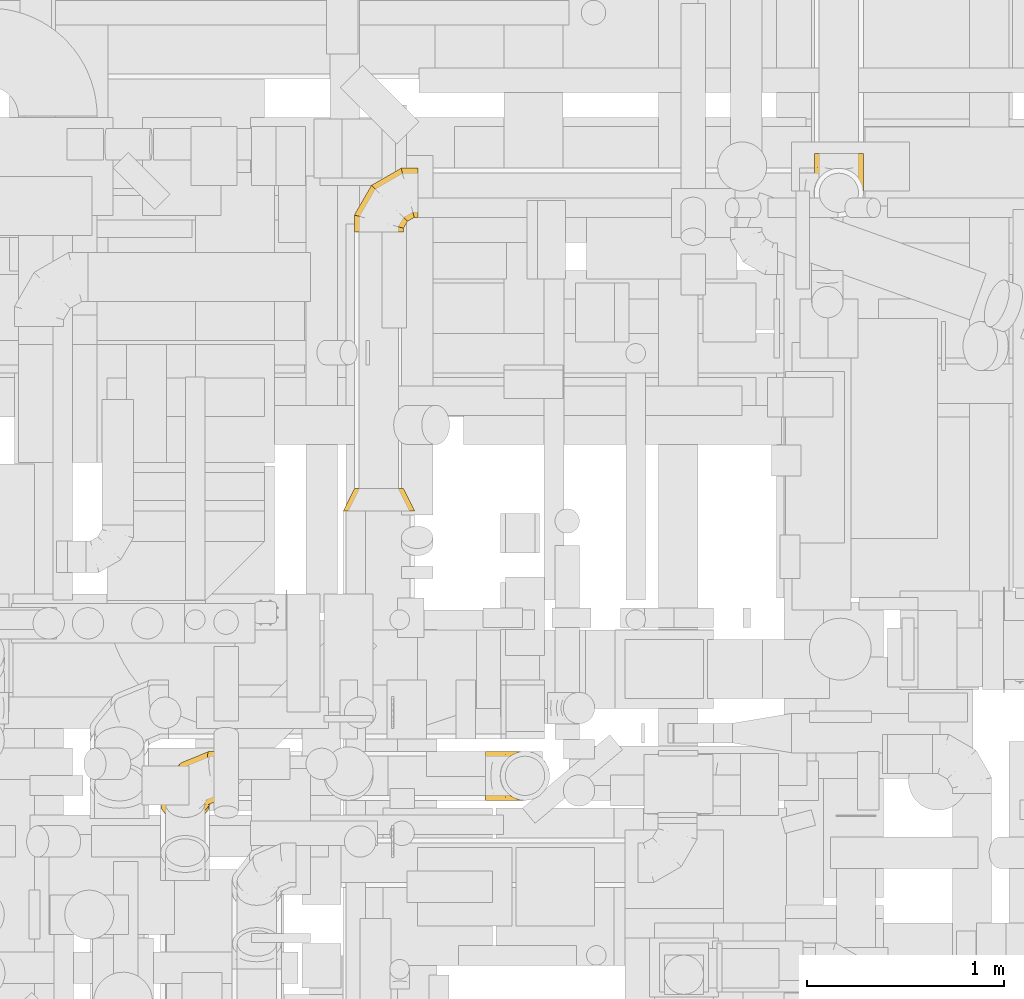
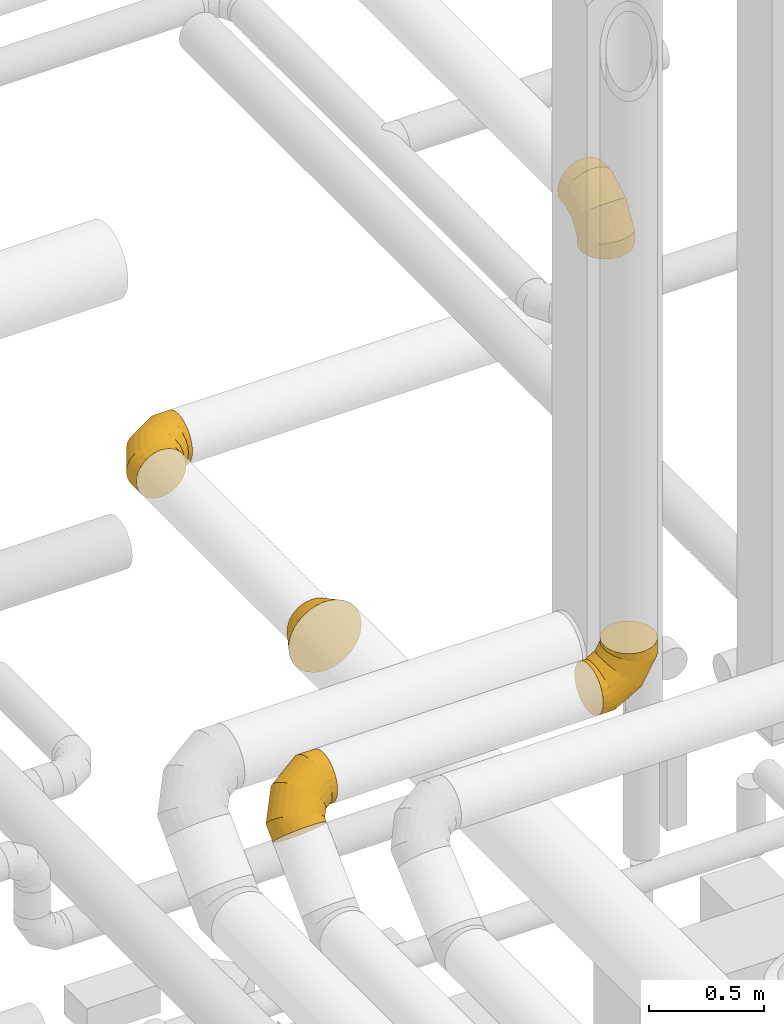
# One storey, part 10 of 337: 5 coverings.
"""IFC2X3 building model written with IfcOpenShell, lengths in millimetres."""

from ifc_helpers import new_model, entity, si_unit, converted_unit, derived_unit, direction, frame, origin, place, context, subcontext, project, spatial, faceted_brep, element, save


model = new_model("IFC2X3")

# Units and contexts
model_context = context("Model", 3, precision=0.01, world=origin(), true_north=direction((6.12303176911189e-17, 1.0)))
body_context = subcontext(model_context, "Body", "Model", "MODEL_VIEW")
ifc_project = project(units=[si_unit("LENGTHUNIT", "METRE", prefix="MILLI"), si_unit("AREAUNIT", "SQUARE_METRE"), si_unit("VOLUMEUNIT", "CUBIC_METRE"), converted_unit("PLANEANGLEUNIT", "DEGREE", entity("IfcRatioMeasure", 0.0174532925199433), si_unit("PLANEANGLEUNIT", "RADIAN"), dimensions=[0, 0, 0, 0, 0, 0, 0]), si_unit("MASSUNIT", "GRAM", prefix="KILO"), derived_unit("MASSDENSITYUNIT", [(si_unit("MASSUNIT", "GRAM", prefix="KILO"), 1), (si_unit("LENGTHUNIT", "METRE"), -3)]), derived_unit("MOMENTOFINERTIAUNIT", [(si_unit("LENGTHUNIT", "METRE"), 4)]), si_unit("TIMEUNIT", "SECOND"), si_unit("FREQUENCYUNIT", "HERTZ"), si_unit("THERMODYNAMICTEMPERATUREUNIT", "DEGREE_CELSIUS"), derived_unit("THERMALTRANSMITTANCEUNIT", [(si_unit("MASSUNIT", "GRAM", prefix="KILO"), 1), (si_unit("THERMODYNAMICTEMPERATUREUNIT", "KELVIN"), -1), (si_unit("TIMEUNIT", "SECOND"), -3)]), derived_unit("VOLUMETRICFLOWRATEUNIT", [(si_unit("LENGTHUNIT", "METRE"), 3), (si_unit("TIMEUNIT", "SECOND"), -1)]), derived_unit("MASSFLOWRATEUNIT", [(si_unit("MASSUNIT", "GRAM", prefix="KILO"), 1), (si_unit("TIMEUNIT", "SECOND"), -1)]), derived_unit("ROTATIONALFREQUENCYUNIT", [(si_unit("TIMEUNIT", "SECOND"), -1)]), si_unit("ELECTRICCURRENTUNIT", "AMPERE"), si_unit("ELECTRICVOLTAGEUNIT", "VOLT"), si_unit("POWERUNIT", "WATT"), si_unit("FORCEUNIT", "NEWTON", prefix="KILO"), si_unit("ILLUMINANCEUNIT", "LUX"), si_unit("LUMINOUSFLUXUNIT", "LUMEN"), si_unit("LUMINOUSINTENSITYUNIT", "CANDELA"), derived_unit("USERDEFINED", [(si_unit("MASSUNIT", "GRAM", prefix="KILO"), -1), (si_unit("LENGTHUNIT", "METRE"), -2), (si_unit("TIMEUNIT", "SECOND"), 3), (si_unit("LUMINOUSFLUXUNIT", "LUMEN"), 1)]), derived_unit("LINEARVELOCITYUNIT", [(si_unit("LENGTHUNIT", "METRE"), 1), (si_unit("TIMEUNIT", "SECOND"), -1)]), si_unit("PRESSUREUNIT", "PASCAL"), derived_unit("USERDEFINED", [(si_unit("LENGTHUNIT", "METRE"), -2), (si_unit("MASSUNIT", "GRAM", prefix="KILO"), 1), (si_unit("TIMEUNIT", "SECOND"), -2)]), derived_unit("LINEARFORCEUNIT", [(si_unit("MASSUNIT", "GRAM", prefix="KILO"), 1), (si_unit("LENGTHUNIT", "METRE"), 1), (si_unit("TIMEUNIT", "SECOND"), -2), (si_unit("LENGTHUNIT", "METRE"), -1)]), derived_unit("PLANARFORCEUNIT", [(si_unit("MASSUNIT", "GRAM", prefix="KILO"), 1), (si_unit("LENGTHUNIT", "METRE"), 1), (si_unit("TIMEUNIT", "SECOND"), -2), (si_unit("LENGTHUNIT", "METRE"), -2)])], contexts=[model_context])

# Site, building, storey
site_placement = place(None, origin())
site = spatial("IfcSite", under=ifc_project, at=site_placement, CompositionType="ELEMENT")
building_placement = place(site_placement, origin())
building = spatial("IfcBuilding", under=site, at=building_placement, CompositionType="ELEMENT")
storey_placement = place(building_placement, origin())
storey = spatial("IfcBuildingStorey", under=building, at=storey_placement, CompositionType="ELEMENT", Elevation=0.0)

# Coverings
covering_1_placement = place(storey_placement, frame((53261.67, 15088.48, 3380.0)))
element("IfcCovering", 1, at=covering_1_placement, inside=storey, PredefinedType="INSULATION", context=body_context, shape_type="Brep", body=[
    faceted_brep([(251.6, 126.6, 0.0), (245.48, 87.97, 0.0), (227.72, 53.12, 0.0), (200.07, 25.47, 0.0), (165.22, 7.71, 0.0), (126.6, 1.6, 0.0), (87.97, 7.71, 0.0), (53.12, 25.47, 0.0), (25.47, 53.12, 0.0), (7.71, 87.97, 0.0), (1.6, 126.6, 0.0), (7.71, 165.22, 0.0), (25.47, 200.07, 0.0), (53.12, 227.72, 0.0), (87.97, 245.48, 0.0), (126.6, 251.6, 0.0), (165.22, 245.48, 0.0), (200.07, 227.72, 0.0), (227.72, 200.07, 0.0), (245.48, 165.22, 0.0), (64.1, 326.6, 308.25), (94.24, 326.6, 320.74), (126.6, 326.6, 325.0), (158.95, 326.6, 320.74), (189.1, 326.6, 308.25), (214.98, 326.6, 288.39), (234.85, 326.6, 262.5), (247.34, 326.6, 232.35), (251.6, 326.6, 200.0), (247.34, 326.6, 167.65), (234.85, 326.6, 137.5), (214.98, 326.6, 111.61), (189.1, 326.6, 91.75), (158.95, 326.6, 79.26), (126.6, 326.6, 75.0), (94.24, 326.6, 79.26), (64.1, 326.6, 91.75), (38.21, 326.6, 111.61), (18.34, 326.6, 137.5), (5.85, 326.6, 167.65), (1.6, 326.6, 200.0), (5.85, 326.6, 232.35), (18.34, 326.6, 262.5), (38.21, 326.6, 288.39), (126.6, 239.51, 325.0), (158.95, 240.65, 320.74), (189.1, 244.0, 308.25), (214.98, 249.32, 288.39), (234.85, 256.26, 262.5), (247.34, 264.34, 232.35), (251.6, 273.01, 200.0), (247.34, 281.67, 167.65), (234.85, 289.75, 137.5), (214.98, 296.69, 111.61), (189.1, 302.01, 91.75), (158.95, 305.36, 79.26), (126.6, 306.5, 75.0), (94.24, 305.36, 79.26), (64.1, 302.01, 91.75), (38.21, 296.69, 111.61), (5.85, 281.67, 167.65), (1.6, 273.01, 200.0), (18.34, 289.75, 137.5), (5.85, 264.34, 232.35), (18.34, 256.26, 262.5), (38.21, 249.32, 288.39), (64.1, 244.0, 308.25), (94.24, 240.65, 320.74), (126.6, 88.68, 237.92), (158.95, 91.8, 234.8), (189.1, 100.94, 225.66), (214.98, 115.48, 211.11), (234.85, 134.43, 192.16), (247.34, 156.5, 170.09), (251.6, 180.19, 146.41), (247.34, 203.87, 122.73), (234.85, 225.94, 100.66), (214.98, 244.89, 81.71), (189.1, 259.43, 67.16), (158.95, 268.57, 58.02), (126.6, 271.69, 54.9), (94.24, 268.57, 58.02), (64.1, 259.43, 67.16), (38.21, 244.89, 81.71), (5.85, 203.87, 122.73), (1.6, 180.19, 146.41), (18.34, 225.94, 100.66), (5.85, 156.5, 170.09), (18.34, 134.43, 192.16), (38.21, 115.48, 211.11), (64.1, 100.94, 225.66), (94.24, 91.8, 234.8), (126.6, 1.6, 87.08), (158.95, 5.85, 85.94), (189.1, 18.34, 82.6), (214.98, 38.21, 77.27), (234.85, 64.1, 70.34), (247.34, 94.24, 62.26), (251.6, 126.6, 53.59), (247.34, 158.95, 44.92), (234.85, 189.1, 36.84), (214.98, 214.98, 29.91), (189.1, 234.85, 24.58), (158.95, 247.34, 21.24), (126.6, 251.6, 20.1), (94.24, 247.34, 21.24), (64.1, 234.85, 24.58), (38.21, 214.98, 29.91), (5.85, 158.95, 44.92), (1.6, 126.6, 53.59), (18.34, 189.1, 36.84), (5.85, 94.24, 62.26), (18.34, 64.1, 70.34), (38.21, 38.21, 77.27), (64.1, 18.34, 82.6), (94.24, 5.85, 85.94)], [[[0, 1, 2, 3, 4, 5, 6, 7, 8, 9, 10, 11, 12, 13, 14, 15, 16, 17, 18, 19]], [[20, 21, 22, 23, 24, 25, 26, 27, 28, 29, 30, 31, 32, 33, 34, 35, 36, 37, 38, 39, 40, 41, 42, 43]], [[22, 44, 45, 23]], [[23, 45, 46, 24]], [[47, 25, 24, 46]], [[25, 47, 48, 26]], [[26, 48, 49, 27]], [[50, 28, 27, 49]], [[51, 52, 30, 29]], [[50, 51, 29, 28]], [[53, 31, 30, 52]], [[54, 55, 33, 32]], [[54, 32, 31, 53]], [[56, 34, 33, 55]], [[57, 58, 36, 35]], [[56, 57, 35, 34]], [[37, 36, 58, 59]], [[60, 61, 40, 39]], [[62, 60, 39, 38]], [[59, 62, 38, 37]], [[41, 40, 61, 63]], [[42, 41, 63, 64]], [[64, 65, 43, 42]], [[21, 20, 66, 67]], [[22, 21, 67, 44]], [[65, 66, 20, 43]], [[45, 44, 68, 69]], [[46, 45, 69, 70]], [[70, 71, 47, 46]], [[48, 47, 71, 72]], [[49, 48, 72, 73]], [[50, 49, 73, 74]], [[75, 76, 52, 51]], [[74, 75, 51, 50]], [[53, 52, 76, 77]], [[78, 79, 55, 54]], [[77, 78, 54, 53]], [[56, 55, 79, 80]], [[81, 82, 58, 57]], [[80, 81, 57, 56]], [[59, 58, 82, 83]], [[84, 85, 61, 60]], [[86, 84, 60, 62]], [[83, 86, 62, 59]], [[63, 61, 85, 87]], [[64, 63, 87, 88]], [[65, 64, 88, 89]], [[67, 66, 90, 91]], [[44, 67, 91, 68]], [[89, 90, 66, 65]], [[69, 68, 92, 93]], [[70, 69, 93, 94]], [[94, 95, 71, 70]], [[72, 71, 95, 96]], [[73, 72, 96, 97]], [[74, 73, 97, 98]], [[99, 100, 76, 75]], [[98, 99, 75, 74]], [[77, 76, 100, 101]], [[102, 103, 79, 78]], [[101, 102, 78, 77]], [[80, 79, 103, 104]], [[105, 106, 82, 81]], [[104, 105, 81, 80]], [[83, 82, 106, 107]], [[108, 109, 85, 84]], [[110, 108, 84, 86]], [[107, 110, 86, 83]], [[87, 85, 109, 111]], [[88, 87, 111, 112]], [[89, 88, 112, 113]], [[91, 90, 114, 115]], [[68, 91, 115, 92]], [[113, 114, 90, 89]], [[93, 5, 4]], [[94, 4, 3]], [[5, 93, 92]], [[93, 4, 94]], [[3, 95, 94]], [[96, 2, 1]], [[97, 1, 0]], [[95, 2, 96]], [[96, 1, 97]], [[0, 98, 97]], [[2, 95, 3]], [[99, 0, 19]], [[100, 19, 18]], [[99, 98, 0]], [[100, 99, 19]], [[18, 101, 100]], [[16, 15, 103]], [[17, 16, 102]], [[102, 101, 17]], [[104, 103, 15]], [[102, 16, 103]], [[17, 101, 18]], [[105, 15, 14]], [[106, 14, 13]], [[105, 104, 15]], [[106, 105, 14]], [[13, 107, 106]], [[110, 12, 11]], [[108, 11, 10]], [[110, 107, 12]], [[109, 108, 10]], [[110, 11, 108]], [[12, 107, 13]], [[111, 10, 9]], [[112, 9, 8]], [[10, 111, 109]], [[111, 9, 112]], [[8, 113, 112]], [[114, 7, 6]], [[115, 6, 5]], [[113, 7, 114]], [[115, 114, 6]], [[92, 115, 5]], [[7, 113, 8]]]),
])
covering_2_placement = place(storey_placement, frame((50921.67, 15015.07, 2973.38)))
element("IfcCovering", 2, at=covering_2_placement, inside=storey, PredefinedType="INSULATION", context=body_context, shape_type="Brep", body=[
    faceted_brep([(126.6, 0.0, 251.6), (87.97, 0.0, 245.48), (53.12, 0.0, 227.72), (25.47, 0.0, 200.07), (7.71, 0.0, 165.22), (1.6, 0.0, 126.6), (7.71, 0.0, 87.97), (25.47, 0.0, 53.12), (53.12, 0.0, 25.47), (87.97, 0.0, 7.71), (126.6, 0.0, 1.6), (165.22, 0.0, 7.71), (200.07, 0.0, 25.47), (227.72, 0.0, 53.12), (245.48, 0.0, 87.97), (251.6, 0.0, 126.6), (245.48, 0.0, 165.22), (227.72, 0.0, 200.07), (200.07, 0.0, 227.72), (165.22, 0.0, 245.48), (326.6, 308.25, 64.1), (326.6, 320.74, 94.24), (326.6, 325.0, 126.6), (326.6, 320.74, 158.95), (326.6, 308.25, 189.1), (326.6, 288.39, 214.98), (326.6, 262.5, 234.85), (326.6, 232.35, 247.34), (326.6, 200.0, 251.6), (326.6, 167.65, 247.34), (326.6, 137.5, 234.85), (326.6, 111.61, 214.98), (326.6, 91.75, 189.1), (326.6, 79.26, 158.95), (326.6, 75.0, 126.6), (326.6, 79.26, 94.24), (326.6, 91.75, 64.1), (326.6, 111.61, 38.21), (326.6, 137.5, 18.34), (326.6, 167.65, 5.85), (326.6, 200.0, 1.6), (326.6, 232.35, 5.85), (326.6, 262.5, 18.34), (326.6, 288.39, 38.21), (239.51, 325.0, 126.6), (240.65, 320.74, 158.95), (244.0, 308.25, 189.1), (249.32, 288.39, 214.98), (256.26, 262.5, 234.85), (264.34, 232.35, 247.34), (273.01, 200.0, 251.6), (281.67, 167.65, 247.34), (289.75, 137.5, 234.85), (296.69, 111.61, 214.98), (302.01, 91.75, 189.1), (305.36, 79.26, 158.95), (306.5, 75.0, 126.6), (305.36, 79.26, 94.24), (302.01, 91.75, 64.1), (296.69, 111.61, 38.21), (281.67, 167.65, 5.85), (273.01, 200.0, 1.6), (289.75, 137.5, 18.34), (264.34, 232.35, 5.85), (256.26, 262.5, 18.34), (249.32, 288.39, 38.21), (244.0, 308.25, 64.1), (240.65, 320.74, 94.24), (88.68, 237.92, 126.6), (91.8, 234.8, 158.95), (100.94, 225.66, 189.1), (115.48, 211.11, 214.98), (134.43, 192.16, 234.85), (156.5, 170.09, 247.34), (180.19, 146.41, 251.6), (203.87, 122.73, 247.34), (225.94, 100.66, 234.85), (244.89, 81.71, 214.98), (259.43, 67.16, 189.1), (268.57, 58.02, 158.95), (271.69, 54.9, 126.6), (268.57, 58.02, 94.24), (259.43, 67.16, 64.1), (244.89, 81.71, 38.21), (203.87, 122.73, 5.85), (180.19, 146.41, 1.6), (225.94, 100.66, 18.34), (156.5, 170.09, 5.85), (134.43, 192.16, 18.34), (115.48, 211.11, 38.21), (100.94, 225.66, 64.1), (91.8, 234.8, 94.24), (1.6, 87.08, 126.6), (5.85, 85.94, 158.95), (18.34, 82.6, 189.1), (38.21, 77.27, 214.98), (64.1, 70.34, 234.85), (94.24, 62.26, 247.34), (126.6, 53.59, 251.6), (158.95, 44.92, 247.34), (189.1, 36.84, 234.85), (214.98, 29.91, 214.98), (234.85, 24.58, 189.1), (247.34, 21.24, 158.95), (251.6, 20.1, 126.6), (247.34, 21.24, 94.24), (234.85, 24.58, 64.1), (214.98, 29.91, 38.21), (158.95, 44.92, 5.85), (126.6, 53.59, 1.6), (189.1, 36.84, 18.34), (94.24, 62.26, 5.85), (64.1, 70.34, 18.34), (38.21, 77.27, 38.21), (18.34, 82.6, 64.1), (5.85, 85.94, 94.24)], [[[0, 1, 2, 3, 4, 5, 6, 7, 8, 9, 10, 11, 12, 13, 14, 15, 16, 17, 18, 19]], [[20, 21, 22, 23, 24, 25, 26, 27, 28, 29, 30, 31, 32, 33, 34, 35, 36, 37, 38, 39, 40, 41, 42, 43]], [[22, 44, 45, 23]], [[23, 45, 46, 24]], [[47, 25, 24, 46]], [[25, 47, 48, 26]], [[26, 48, 49, 27]], [[50, 28, 27, 49]], [[51, 52, 30, 29]], [[50, 51, 29, 28]], [[53, 31, 30, 52]], [[54, 55, 33, 32]], [[54, 32, 31, 53]], [[56, 34, 33, 55]], [[57, 58, 36, 35]], [[56, 57, 35, 34]], [[37, 36, 58, 59]], [[60, 61, 40, 39]], [[62, 60, 39, 38]], [[59, 62, 38, 37]], [[41, 40, 61, 63]], [[42, 41, 63, 64]], [[64, 65, 43, 42]], [[21, 20, 66, 67]], [[22, 21, 67, 44]], [[65, 66, 20, 43]], [[45, 44, 68, 69]], [[46, 45, 69, 70]], [[70, 71, 47, 46]], [[48, 47, 71, 72]], [[49, 48, 72, 73]], [[50, 49, 73, 74]], [[75, 76, 52, 51]], [[74, 75, 51, 50]], [[53, 52, 76, 77]], [[78, 79, 55, 54]], [[77, 78, 54, 53]], [[56, 55, 79, 80]], [[81, 82, 58, 57]], [[80, 81, 57, 56]], [[59, 58, 82, 83]], [[84, 85, 61, 60]], [[86, 84, 60, 62]], [[83, 86, 62, 59]], [[63, 61, 85, 87]], [[64, 63, 87, 88]], [[65, 64, 88, 89]], [[67, 66, 90, 91]], [[44, 67, 91, 68]], [[89, 90, 66, 65]], [[69, 68, 92, 93]], [[70, 69, 93, 94]], [[94, 95, 71, 70]], [[72, 71, 95, 96]], [[73, 72, 96, 97]], [[74, 73, 97, 98]], [[99, 100, 76, 75]], [[98, 99, 75, 74]], [[77, 76, 100, 101]], [[102, 103, 79, 78]], [[101, 102, 78, 77]], [[80, 79, 103, 104]], [[105, 106, 82, 81]], [[104, 105, 81, 80]], [[83, 82, 106, 107]], [[108, 109, 85, 84]], [[110, 108, 84, 86]], [[107, 110, 86, 83]], [[87, 85, 109, 111]], [[88, 87, 111, 112]], [[89, 88, 112, 113]], [[91, 90, 114, 115]], [[68, 91, 115, 92]], [[113, 114, 90, 89]], [[93, 5, 4]], [[94, 4, 3]], [[5, 93, 92]], [[93, 4, 94]], [[3, 95, 94]], [[96, 2, 1]], [[97, 1, 0]], [[95, 2, 96]], [[96, 1, 97]], [[0, 98, 97]], [[2, 95, 3]], [[99, 0, 19]], [[100, 19, 18]], [[99, 98, 0]], [[100, 99, 19]], [[18, 101, 100]], [[16, 15, 103]], [[17, 16, 102]], [[102, 101, 17]], [[104, 103, 15]], [[102, 16, 103]], [[17, 101, 18]], [[105, 15, 14]], [[106, 14, 13]], [[105, 104, 15]], [[106, 105, 14]], [[13, 107, 106]], [[110, 12, 11]], [[108, 11, 10]], [[110, 107, 12]], [[109, 108, 10]], [[110, 11, 108]], [[12, 107, 13]], [[111, 10, 9]], [[112, 9, 8]], [[10, 111, 109]], [[111, 9, 112]], [[8, 113, 112]], [[114, 7, 6]], [[115, 6, 5]], [[113, 7, 114]], [[115, 114, 6]], [[92, 115, 5]], [[7, 113, 8]]]),
])
covering_3_placement = place(storey_placement, frame((50864.17, 13595.07, 2915.88)))
element("IfcCovering", 3, at=covering_3_placement, inside=storey, PredefinedType="INSULATION", context=body_context, shape_type="Brep", body=[
    faceted_brep([(184.1, 115.0, 309.1), (222.72, 115.0, 302.98), (257.57, 115.0, 285.22), (271.4, 115.0, 271.4), (285.22, 115.0, 257.57), (302.98, 115.0, 222.72), (309.1, 115.0, 184.1), (302.98, 115.0, 145.47), (285.22, 115.0, 110.62), (271.4, 115.0, 96.8), (257.57, 115.0, 82.97), (222.72, 115.0, 65.21), (184.1, 115.0, 59.1), (145.47, 115.0, 65.21), (110.62, 115.0, 82.97), (96.8, 115.0, 96.8), (82.97, 115.0, 110.62), (65.21, 115.0, 145.47), (59.1, 115.0, 184.1), (65.21, 115.0, 222.72), (82.97, 115.0, 257.57), (96.8, 115.0, 271.4), (110.62, 115.0, 285.22), (145.47, 115.0, 302.98), (136.86, 0.0, 360.38), (92.85, 0.0, 342.14), (55.05, 0.0, 313.14), (26.05, 0.0, 275.35), (7.81, 0.0, 231.33), (1.6, 0.0, 184.1), (7.81, 0.0, 136.86), (26.05, 0.0, 92.85), (55.05, 0.0, 55.05), (92.85, 0.0, 26.05), (136.86, 0.0, 7.81), (184.1, 0.0, 1.6), (231.33, 0.0, 7.81), (275.35, 0.0, 26.05), (313.14, 0.0, 55.05), (342.14, 0.0, 92.85), (360.38, 0.0, 136.86), (366.6, 0.0, 184.1), (360.38, 0.0, 231.33), (342.14, 0.0, 275.35), (313.14, 0.0, 313.14), (275.35, 0.0, 342.14), (231.33, 0.0, 360.38), (184.1, 0.0, 366.6), (335.62, 56.45, 155.07), (327.19, 78.81, 184.1), (328.08, 53.31, 124.46), (312.09, 56.04, 97.6), (184.1, 78.81, 41.0), (213.12, 56.45, 32.57), (243.73, 53.31, 40.11), (293.1, 56.68, 75.09), (270.59, 56.04, 56.1), (155.07, 56.45, 32.57), (124.46, 53.31, 40.11), (97.6, 56.04, 56.1), (41.0, 78.81, 184.1), (32.57, 56.45, 155.07), (40.11, 53.31, 124.46), (75.09, 56.68, 75.09), (56.1, 56.04, 97.6), (32.57, 56.45, 213.12), (40.11, 53.31, 243.74), (56.1, 56.04, 270.59), (184.1, 78.81, 327.19), (155.07, 56.45, 335.62), (124.46, 53.31, 328.08), (75.09, 56.68, 293.1), (97.6, 56.04, 312.09), (213.12, 56.45, 335.62), (243.73, 53.31, 328.08), (270.59, 56.04, 312.09), (335.62, 56.45, 213.12), (328.08, 53.31, 243.74), (293.1, 56.68, 293.1), (312.09, 56.04, 270.59)], [[[0, 1, 2, 3, 4, 5, 6, 7, 8, 9, 10, 11, 12, 13, 14, 15, 16, 17, 18, 19, 20, 21, 22, 23]], [[24, 25, 26, 27, 28, 29, 30, 31, 32, 33, 34, 35, 36, 37, 38, 39, 40, 41, 42, 43, 44, 45, 46, 47]], [[48, 6, 49, 41]], [[50, 39, 51]], [[40, 39, 50]], [[48, 40, 50]], [[41, 40, 48]], [[35, 52, 12, 53]], [[7, 50, 8]], [[7, 6, 48]], [[51, 8, 50]], [[54, 37, 36]], [[35, 53, 36]], [[12, 11, 53]], [[55, 51, 38]], [[37, 54, 56]], [[53, 54, 36]], [[54, 10, 56]], [[53, 11, 54]], [[56, 55, 38]], [[10, 54, 11]], [[7, 48, 50]], [[9, 8, 55, 10]], [[39, 38, 51]], [[38, 37, 56]], [[55, 8, 51]], [[10, 55, 56]], [[57, 12, 52, 35]], [[58, 33, 59]], [[34, 33, 58]], [[57, 34, 58]], [[35, 34, 57]], [[29, 60, 18, 61]], [[13, 58, 14]], [[13, 12, 57]], [[59, 14, 58]], [[62, 31, 30]], [[29, 61, 30]], [[18, 17, 61]], [[63, 59, 32]], [[31, 62, 64]], [[61, 62, 30]], [[62, 16, 64]], [[61, 17, 62]], [[64, 63, 32]], [[16, 62, 17]], [[13, 57, 58]], [[15, 14, 63, 16]], [[33, 32, 59]], [[32, 31, 64]], [[63, 14, 59]], [[16, 63, 64]], [[65, 18, 60, 29]], [[66, 27, 67]], [[28, 27, 66]], [[65, 28, 66]], [[29, 28, 65]], [[47, 68, 0, 69]], [[19, 66, 20]], [[19, 18, 65]], [[67, 20, 66]], [[70, 25, 24]], [[47, 69, 24]], [[0, 23, 69]], [[71, 67, 26]], [[25, 70, 72]], [[69, 70, 24]], [[70, 22, 72]], [[69, 23, 70]], [[72, 71, 26]], [[22, 70, 23]], [[19, 65, 66]], [[21, 20, 71, 22]], [[27, 26, 67]], [[26, 25, 72]], [[71, 20, 67]], [[22, 71, 72]], [[73, 0, 68, 47]], [[74, 45, 75]], [[46, 45, 74]], [[73, 46, 74]], [[47, 46, 73]], [[41, 49, 6, 76]], [[1, 74, 2]], [[1, 0, 73]], [[75, 2, 74]], [[77, 43, 42]], [[41, 76, 42]], [[6, 5, 76]], [[78, 75, 44]], [[43, 77, 79]], [[76, 77, 42]], [[77, 4, 79]], [[76, 5, 77]], [[79, 78, 44]], [[4, 77, 5]], [[1, 73, 74]], [[3, 2, 78, 4]], [[45, 44, 75]], [[44, 43, 79]], [[78, 2, 75]], [[4, 78, 79]]]),
])
covering_4_placement = place(storey_placement, frame((49935.95, 12017.64, 3218.6)))
element("IfcCovering", 4, at=covering_4_placement, inside=storey, PredefinedType="INSULATION", context=body_context, shape_type="Brep", body=[
    faceted_brep([(200.07, 18.48, 161.49), (165.22, 5.92, 174.05), (126.6, 1.6, 178.37), (87.97, 5.92, 174.05), (53.12, 18.48, 161.49), (25.47, 38.03, 141.94), (7.71, 62.67, 117.3), (1.6, 89.98, 89.98), (7.71, 117.3, 62.67), (25.47, 141.94, 38.03), (53.12, 161.49, 18.48), (87.97, 174.05, 5.92), (126.6, 178.37, 1.6), (165.22, 174.05, 5.92), (200.07, 161.49, 18.48), (227.72, 141.94, 38.03), (245.48, 117.3, 62.67), (251.6, 89.98, 89.98), (245.48, 62.67, 117.3), (227.72, 38.03, 141.94), (326.6, 352.15, 263.76), (326.6, 339.66, 293.9), (326.6, 319.79, 319.79), (326.6, 293.9, 339.66), (326.6, 263.76, 352.15), (326.6, 231.4, 356.4), (326.6, 199.05, 352.15), (326.6, 168.9, 339.66), (326.6, 143.02, 319.79), (326.6, 123.15, 293.9), (326.6, 110.66, 263.76), (326.6, 106.4, 231.4), (326.6, 110.66, 199.05), (326.6, 123.15, 168.9), (326.6, 143.02, 143.02), (326.6, 168.9, 123.15), (326.6, 199.05, 110.66), (326.6, 231.4, 106.4), (326.6, 263.76, 110.66), (326.6, 293.9, 123.15), (326.6, 319.79, 143.02), (326.6, 339.66, 168.9), (326.6, 352.15, 199.05), (326.6, 356.4, 231.4), (239.51, 319.79, 319.79), (240.65, 293.9, 339.66), (244.0, 263.76, 352.15), (249.32, 231.4, 356.4), (256.26, 199.05, 352.15), (264.34, 168.9, 339.66), (273.01, 143.02, 319.79), (281.67, 123.15, 293.9), (289.75, 110.66, 263.76), (296.69, 106.4, 231.4), (302.01, 110.66, 199.05), (305.36, 123.15, 168.9), (306.5, 143.02, 143.02), (305.36, 168.9, 123.15), (302.01, 199.05, 110.66), (296.69, 231.4, 106.4), (281.67, 293.9, 123.15), (273.01, 319.79, 143.02), (289.75, 263.76, 110.66), (264.34, 339.66, 168.9), (256.26, 352.15, 199.05), (249.32, 356.4, 231.4), (244.0, 352.15, 263.76), (240.65, 339.66, 293.9), (88.68, 258.22, 258.22), (91.8, 233.13, 278.89), (100.94, 205.35, 293.74), (115.48, 176.76, 301.76), (134.43, 149.32, 302.41), (156.5, 124.88, 295.63), (180.19, 105.12, 281.9), (203.87, 91.39, 262.14), (225.94, 84.61, 237.71), (244.89, 85.26, 210.26), (259.43, 93.28, 181.67), (268.57, 108.13, 153.89), (271.69, 128.81, 128.81), (268.57, 153.89, 108.13), (259.43, 181.67, 93.28), (244.89, 210.26, 85.26), (203.87, 262.14, 91.39), (180.19, 281.9, 105.12), (225.94, 237.71, 84.61), (156.5, 295.63, 124.88), (134.43, 302.41, 149.32), (115.48, 301.76, 176.76), (100.94, 293.74, 205.35), (91.8, 278.89, 233.13), (1.6, 151.56, 151.56), (5.85, 127.88, 173.63), (18.34, 104.19, 192.58), (38.21, 82.12, 207.12), (64.1, 63.17, 216.27), (94.24, 48.63, 219.38), (126.6, 39.49, 216.27), (158.95, 36.37, 207.12), (189.1, 39.49, 192.58), (214.98, 48.63, 173.63), (234.85, 63.17, 151.56), (247.34, 82.12, 127.88), (251.6, 104.19, 104.19), (247.34, 127.88, 82.12), (234.85, 151.56, 63.17), (214.98, 173.63, 48.63), (158.95, 207.12, 36.37), (126.6, 216.27, 39.49), (189.1, 192.58, 39.49), (94.24, 219.38, 48.63), (64.1, 216.27, 63.17), (38.21, 207.12, 82.12), (18.34, 192.58, 104.19), (5.85, 173.63, 127.88)], [[[0, 1, 2, 3, 4, 5, 6, 7, 8, 9, 10, 11, 12, 13, 14, 15, 16, 17, 18, 19]], [[20, 21, 22, 23, 24, 25, 26, 27, 28, 29, 30, 31, 32, 33, 34, 35, 36, 37, 38, 39, 40, 41, 42, 43]], [[22, 44, 45, 23]], [[23, 45, 46, 24]], [[47, 25, 24, 46]], [[25, 47, 48, 26]], [[26, 48, 49, 27]], [[50, 28, 27, 49]], [[51, 52, 30, 29]], [[50, 51, 29, 28]], [[53, 31, 30, 52]], [[54, 55, 33, 32]], [[54, 32, 31, 53]], [[56, 34, 33, 55]], [[57, 58, 36, 35]], [[56, 57, 35, 34]], [[37, 36, 58, 59]], [[60, 61, 40, 39]], [[62, 60, 39, 38]], [[59, 62, 38, 37]], [[41, 40, 61, 63]], [[42, 41, 63, 64]], [[64, 65, 43, 42]], [[21, 20, 66, 67]], [[22, 21, 67, 44]], [[65, 66, 20, 43]], [[45, 44, 68, 69]], [[46, 45, 69, 70]], [[70, 71, 47, 46]], [[48, 47, 71, 72]], [[49, 48, 72, 73]], [[50, 49, 73, 74]], [[75, 76, 52, 51]], [[74, 75, 51, 50]], [[53, 52, 76, 77]], [[78, 79, 55, 54]], [[77, 78, 54, 53]], [[56, 55, 79, 80]], [[81, 82, 58, 57]], [[80, 81, 57, 56]], [[59, 58, 82, 83]], [[84, 85, 61, 60]], [[86, 84, 60, 62]], [[83, 86, 62, 59]], [[63, 61, 85, 87]], [[64, 63, 87, 88]], [[65, 64, 88, 89]], [[67, 66, 90, 91]], [[44, 67, 91, 68]], [[89, 90, 66, 65]], [[69, 68, 92, 93]], [[70, 69, 93, 94]], [[94, 95, 71, 70]], [[72, 71, 95, 96]], [[73, 72, 96, 97]], [[74, 73, 97, 98]], [[99, 100, 76, 75]], [[98, 99, 75, 74]], [[77, 76, 100, 101]], [[102, 103, 79, 78]], [[101, 102, 78, 77]], [[80, 79, 103, 104]], [[105, 106, 82, 81]], [[104, 105, 81, 80]], [[83, 82, 106, 107]], [[108, 109, 85, 84]], [[110, 108, 84, 86]], [[107, 110, 86, 83]], [[87, 85, 109, 111]], [[88, 87, 111, 112]], [[89, 88, 112, 113]], [[91, 90, 114, 115]], [[68, 91, 115, 92]], [[113, 114, 90, 89]], [[93, 7, 6]], [[94, 6, 5]], [[7, 93, 92]], [[93, 6, 94]], [[5, 95, 94]], [[96, 4, 3]], [[97, 3, 2]], [[95, 4, 96]], [[96, 3, 97]], [[2, 98, 97]], [[4, 95, 5]], [[99, 2, 1]], [[100, 1, 0]], [[99, 98, 2]], [[100, 99, 1]], [[0, 101, 100]], [[18, 17, 103]], [[19, 18, 102]], [[102, 101, 19]], [[104, 103, 17]], [[102, 18, 103]], [[19, 101, 0]], [[105, 17, 16]], [[106, 16, 15]], [[105, 104, 17]], [[106, 105, 16]], [[15, 107, 106]], [[110, 14, 13]], [[108, 13, 12]], [[110, 107, 14]], [[109, 108, 12]], [[110, 13, 108]], [[14, 107, 15]], [[111, 12, 11]], [[112, 11, 10]], [[12, 111, 109]], [[111, 11, 112]], [[10, 113, 112]], [[114, 9, 8]], [[115, 8, 7]], [[113, 9, 114]], [[115, 114, 8]], [[92, 115, 7]], [[9, 113, 10]]]),
])
covering_5_placement = place(storey_placement, frame((51591.72, 12122.45, 3323.4)))
element("IfcCovering", 5, at=covering_5_placement, inside=storey, PredefinedType="INSULATION", context=body_context, shape_type="Brep", body=[
    faceted_brep([(161.37, 7.71, 326.6), (200.0, 1.6, 326.6), (238.63, 7.71, 326.6), (273.47, 25.47, 326.6), (301.13, 53.12, 326.6), (318.88, 87.97, 326.6), (325.0, 126.6, 326.6), (318.88, 165.22, 326.6), (301.13, 200.07, 326.6), (273.47, 227.72, 326.6), (238.63, 245.48, 326.6), (200.0, 251.6, 326.6), (161.37, 245.48, 326.6), (126.53, 227.72, 326.6), (98.87, 200.07, 326.6), (81.12, 165.22, 326.6), (75.0, 126.6, 326.6), (81.12, 87.97, 326.6), (98.87, 53.12, 326.6), (126.53, 25.47, 326.6), (0.0, 189.1, 18.34), (0.0, 158.95, 5.85), (0.0, 126.6, 1.6), (0.0, 94.24, 5.85), (0.0, 64.1, 18.34), (0.0, 38.21, 38.21), (0.0, 18.34, 64.1), (0.0, 5.85, 94.24), (0.0, 1.6, 126.6), (0.0, 5.85, 158.95), (0.0, 18.34, 189.1), (0.0, 38.21, 214.98), (0.0, 64.1, 234.85), (0.0, 94.24, 247.34), (0.0, 126.6, 251.6), (0.0, 158.95, 247.34), (0.0, 189.1, 234.85), (0.0, 214.98, 214.98), (0.0, 234.85, 189.1), (0.0, 247.34, 158.95), (0.0, 251.6, 126.6), (0.0, 247.34, 94.24), (0.0, 234.85, 64.1), (0.0, 214.98, 38.21), (87.08, 126.6, 1.6), (85.94, 94.24, 5.85), (82.6, 64.1, 18.34), (77.27, 38.21, 38.21), (70.34, 18.34, 64.1), (62.26, 5.85, 94.24), (53.59, 1.6, 126.6), (44.92, 5.85, 158.95), (36.84, 18.34, 189.1), (29.91, 38.21, 214.98), (24.58, 64.1, 234.85), (21.24, 94.24, 247.34), (20.1, 126.6, 251.6), (21.24, 158.95, 247.34), (24.58, 189.1, 234.85), (29.91, 214.98, 214.98), (44.92, 247.34, 158.95), (53.59, 251.6, 126.6), (36.84, 234.85, 189.1), (62.26, 247.34, 94.24), (70.34, 234.85, 64.1), (77.27, 214.98, 38.21), (82.6, 189.1, 18.34), (85.94, 158.95, 5.85), (237.92, 126.6, 88.68), (234.8, 94.24, 91.8), (225.66, 64.1, 100.94), (211.11, 38.21, 115.48), (192.16, 18.34, 134.43), (170.09, 5.85, 156.5), (146.41, 1.6, 180.19), (122.73, 5.85, 203.87), (100.66, 18.34, 225.94), (81.71, 38.21, 244.89), (67.16, 64.1, 259.43), (58.02, 94.24, 268.57), (54.9, 126.6, 271.69), (58.02, 158.95, 268.57), (67.16, 189.1, 259.43), (81.71, 214.98, 244.89), (122.73, 247.34, 203.87), (146.41, 251.6, 180.19), (100.66, 234.85, 225.94), (170.09, 247.34, 156.5), (192.16, 234.85, 134.43), (211.11, 214.98, 115.48), (225.66, 189.1, 100.94), (234.8, 158.95, 91.8), (325.0, 126.6, 239.51), (320.74, 94.24, 240.65), (308.25, 64.1, 244.0), (288.39, 38.21, 249.32), (262.5, 18.34, 256.26), (232.35, 5.85, 264.34), (200.0, 1.6, 273.01), (167.65, 5.85, 281.67), (137.5, 18.34, 289.75), (111.61, 38.21, 296.69), (91.75, 64.1, 302.01), (79.26, 94.24, 305.36), (75.0, 126.6, 306.5), (79.26, 158.95, 305.36), (91.75, 189.1, 302.01), (111.61, 214.98, 296.69), (167.65, 247.34, 281.67), (200.0, 251.6, 273.01), (137.5, 234.85, 289.75), (232.35, 247.34, 264.34), (262.5, 234.85, 256.26), (288.39, 214.98, 249.32), (308.25, 189.1, 244.0), (320.74, 158.95, 240.65)], [[[0, 1, 2, 3, 4, 5, 6, 7, 8, 9, 10, 11, 12, 13, 14, 15, 16, 17, 18, 19]], [[20, 21, 22, 23, 24, 25, 26, 27, 28, 29, 30, 31, 32, 33, 34, 35, 36, 37, 38, 39, 40, 41, 42, 43]], [[22, 44, 45, 23]], [[23, 45, 46, 24]], [[47, 25, 24, 46]], [[25, 47, 48, 26]], [[26, 48, 49, 27]], [[50, 28, 27, 49]], [[51, 52, 30, 29]], [[50, 51, 29, 28]], [[53, 31, 30, 52]], [[54, 55, 33, 32]], [[54, 32, 31, 53]], [[56, 34, 33, 55]], [[57, 58, 36, 35]], [[56, 57, 35, 34]], [[37, 36, 58, 59]], [[60, 61, 40, 39]], [[62, 60, 39, 38]], [[59, 62, 38, 37]], [[41, 40, 61, 63]], [[42, 41, 63, 64]], [[64, 65, 43, 42]], [[21, 20, 66, 67]], [[22, 21, 67, 44]], [[65, 66, 20, 43]], [[45, 44, 68, 69]], [[46, 45, 69, 70]], [[70, 71, 47, 46]], [[48, 47, 71, 72]], [[49, 48, 72, 73]], [[50, 49, 73, 74]], [[75, 76, 52, 51]], [[74, 75, 51, 50]], [[53, 52, 76, 77]], [[78, 79, 55, 54]], [[77, 78, 54, 53]], [[56, 55, 79, 80]], [[81, 82, 58, 57]], [[80, 81, 57, 56]], [[59, 58, 82, 83]], [[84, 85, 61, 60]], [[86, 84, 60, 62]], [[83, 86, 62, 59]], [[63, 61, 85, 87]], [[64, 63, 87, 88]], [[65, 64, 88, 89]], [[67, 66, 90, 91]], [[44, 67, 91, 68]], [[89, 90, 66, 65]], [[69, 68, 92, 93]], [[70, 69, 93, 94]], [[94, 95, 71, 70]], [[72, 71, 95, 96]], [[73, 72, 96, 97]], [[74, 73, 97, 98]], [[99, 100, 76, 75]], [[98, 99, 75, 74]], [[77, 76, 100, 101]], [[102, 103, 79, 78]], [[101, 102, 78, 77]], [[80, 79, 103, 104]], [[105, 106, 82, 81]], [[104, 105, 81, 80]], [[83, 82, 106, 107]], [[108, 109, 85, 84]], [[110, 108, 84, 86]], [[107, 110, 86, 83]], [[87, 85, 109, 111]], [[88, 87, 111, 112]], [[89, 88, 112, 113]], [[91, 90, 114, 115]], [[68, 91, 115, 92]], [[113, 114, 90, 89]], [[93, 6, 5]], [[94, 5, 4]], [[6, 93, 92]], [[93, 5, 94]], [[4, 95, 94]], [[96, 3, 2]], [[97, 2, 1]], [[95, 3, 96]], [[96, 2, 97]], [[1, 98, 97]], [[3, 95, 4]], [[99, 1, 0]], [[100, 0, 19]], [[99, 98, 1]], [[100, 99, 0]], [[19, 101, 100]], [[17, 16, 103]], [[18, 17, 102]], [[102, 101, 18]], [[104, 103, 16]], [[102, 17, 103]], [[18, 101, 19]], [[105, 16, 15]], [[106, 15, 14]], [[105, 104, 16]], [[106, 105, 15]], [[14, 107, 106]], [[110, 13, 12]], [[108, 12, 11]], [[110, 107, 13]], [[109, 108, 11]], [[110, 12, 108]], [[13, 107, 14]], [[111, 11, 10]], [[112, 10, 9]], [[11, 111, 109]], [[111, 10, 112]], [[9, 113, 112]], [[114, 8, 7]], [[115, 7, 6]], [[113, 8, 114]], [[115, 114, 7]], [[92, 115, 6]], [[8, 113, 9]]]),
])

save(model, "model.ifc")
